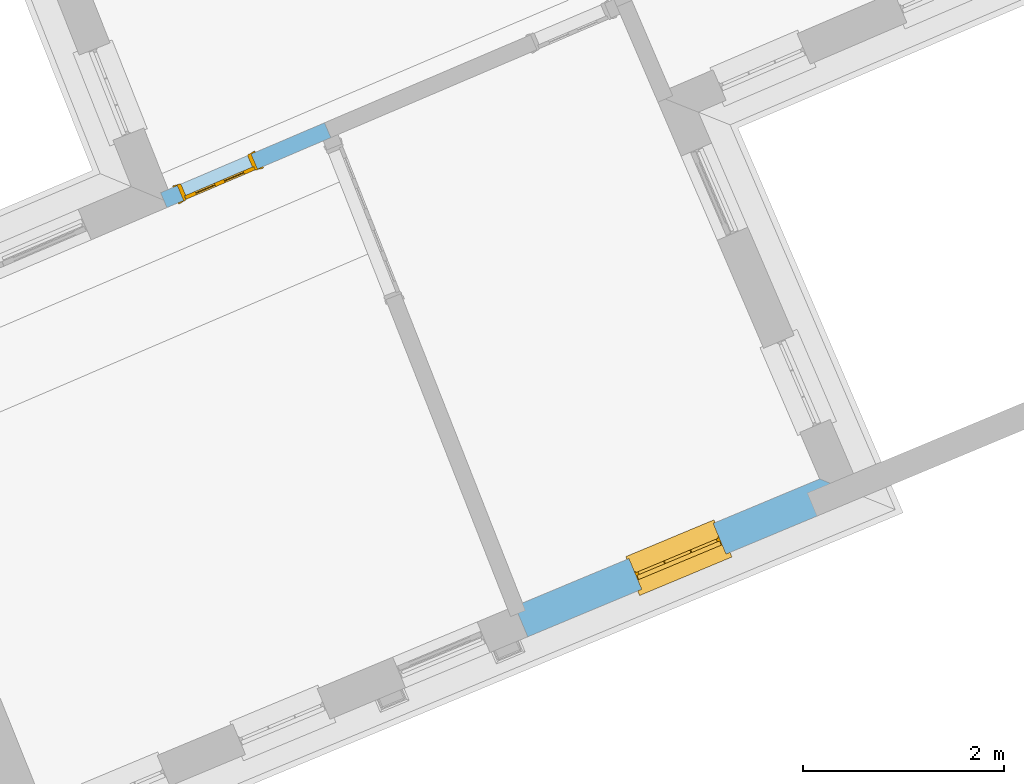
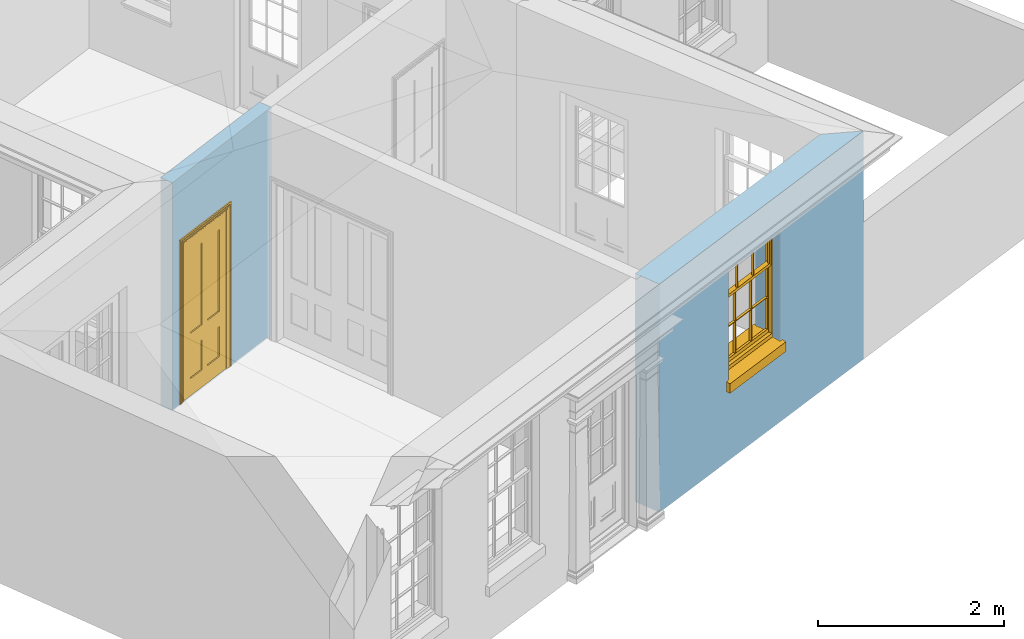
# One storey, part 5 of 19: 1 door, 1 window, 2 openings, plus 2 elements that do not belong to this part.
"""IFC2X3 building model written with IfcOpenShell, lengths in metres."""

from ifc_helpers import new_model, si_unit, frame, origin, place, context, subcontext, project, spatial, polyline, outline, extrude, faceted_brep, material, layer, layer_set, layer_usage, element, fill, save


model = new_model("IFC2X3")

# Units and contexts
model_context = context("Model", 3, world=origin())
body_context = subcontext(model_context, "Body", "Model", "MODEL_VIEW")
ifc_project = project(units=[si_unit("PLANEANGLEUNIT", "RADIAN"), si_unit("MASSUNIT", "GRAM", prefix="KILO"), si_unit("FORCEUNIT", "NEWTON", prefix="KILO"), si_unit("LENGTHUNIT", "METRE")], contexts=[model_context])

# Site, building, storey
site_placement = place(None, origin())
site = spatial("IfcSite", under=ifc_project, at=site_placement, CompositionType="ELEMENT")
building_placement = place(None, origin())
building = spatial("IfcBuilding", under=site, at=building_placement, Name="Building plot-0", CompositionType="ELEMENT")
storey_placement = place(None, origin())
storey = spatial("IfcBuildingStorey", under=building, at=storey_placement, Name="Floor 0", CompositionType="ELEMENT", Elevation=0.0)

# Wall, opening, window
ifc_material_1 = material(Name="Masonry")
ifc_layer_1 = layer(ifc_material_1, 0.33, ventilated=False)
ifc_layer_set_1 = layer_set([ifc_layer_1], Name="My Wall")
ifc_layer_usage_1 = layer_usage(ifc_layer_set_1, "AXIS2", "NEGATIVE", 0.08)
wall_1_placement = place(storey_placement, origin())
wall_1 = element("IfcWallStandardCase", 1, at=wall_1_placement, inside=storey, material=ifc_layer_usage_1, Name="exterior", context=body_context, shape_type="SweptSolid", body=[
    extrude(outline(polyline([(21.1736725194713, 22.591048436714), (21.3007494176732, 22.2864971898878), (24.6386025500617, 23.6792480885884), (24.2038471452139, 23.8554175583724), (21.1736725194713, 22.591048436714)])), origin(), (0.0, 0.0, 1.0), 3.0),
])
opening_1_placement = place(storey_placement, frame((0.0, 0.0, 1.05)))
opening_1 = element("IfcOpeningElement", 2, at=opening_1_placement, cuts=wall_1, Name="Opening", ObjectType="Opening", context=body_context, shape_type="SweptSolid", body=[
    extrude(outline(polyline([(22.4332195273928, 22.7590310913225), (23.2730426625801, 23.1094552651521), (23.1459657643782, 23.4140065119782), (22.3061426291909, 23.0635823381487), (22.4332195273928, 22.7590310913225)])), origin(), (0.0, 0.0, 1.0), 1.445),
])
window_placement = place(storey_placement, frame((22.3369491499671, 22.9897517328575, 1.05), z_axis=(0.0, 0.0, 1.0), x_axis=(0.839823135187327, 0.350424173829566, 0.0)))
window = element("IfcWindow", 3, at=window_placement, inside=storey, Name="kitchen street window", OverallHeight=1.445, OverallWidth=0.91, context=body_context, shape_type="Brep", held_by="IfcProductRepresentation", body=[
    faceted_brep([(0.876875, -0.105, 0.999097), (0.876875, -0.105, 1.411875), (0.9, -0.105, 1.435), (0.033125, -0.105, 1.411875), (0.033125, -0.105, 0.999097), (0.01, -0.105, 1.435), (0.033125, -0.135, 1.411875), (0.01, -0.135, 1.435), (0.033125, -0.135, 0.999097), (0.876875, -0.135, 1.411875), (0.876875, -0.135, 0.999097), (0.9, -0.135, 1.435), (0.033125, -0.105, 0.960972), (0.01, -0.105, 0.960972), (0.033125, -0.105, 0.548195), (0.876875, -0.105, 0.960972), (0.876875, -0.105, 0.548195), (0.9, -0.105, 0.960972), (0.876875, -0.105, 0.538195), (0.876875, -0.105, 0.125417), (0.9, -0.105, 0.077167), (0.033125, -0.105, 0.125417), (0.033125, -0.105, 0.538195), (0.01, -0.105, 0.077167), (0.9, -0.135, 0.960972), (0.01, -0.135, 0.960972), (-0.0425, -0.25, 0.01), (-0.0425, -0.3, 0.001667), (0.0, -0.25, 0.01), (0.9525, -0.25, 0.01), (0.91, -0.25, 0.01), (0.9525, -0.3, 0.001667), (-0.02, 0.08, 0.077167), (0.0, 0.08, 0.077167), (-0.02, 0.11, 0.077167), (0.0, -0.06, 0.077167), (0.01, -0.06, 0.077167), (0.91, -0.06, 0.077167), (0.91, 0.08, 0.077167), (0.9, -0.06, 0.077167), (0.93, 0.08, 0.077167), (0.93, 0.11, 0.077167), (0.01, -0.105, 0.999097), (0.01, -0.075, 0.999097), (0.9, -0.105, 0.999097), (0.9, -0.075, 0.999097), (0.876875, -0.075, 0.125417), (0.876875, -0.075, 0.538195), (0.9, -0.075, 0.077167), (0.876875, -0.075, 0.548195), (0.876875, -0.075, 0.960972), (0.033125, -0.075, 0.125417), (0.01, -0.075, 0.077167), (0.033125, -0.075, 0.538195), (0.033125, -0.075, 0.960972), (0.033125, -0.075, 0.548195), (-0.02, 0.08, 0.052167), (-0.02, 0.11, 0.052167), (0.93, 0.11, 0.052167), (0.93, 0.08, 0.052167), (0.91, 0.08, 0.052167), (0.0, 0.08, 0.052167), (0.91, -0.15, 0.026667), (0.0, -0.15, 0.026667), (-0.0425, -0.3, -0.123333), (0.9525, -0.3, -0.123333), (-0.0425, -0.25, -0.123333), (0.9525, -0.25, -0.123333), (0.01, -0.06, 1.435), (0.9, -0.06, 1.435), (0.0, -0.06, 1.445), (0.91, -0.06, 1.445), (0.01, -0.15, 0.077167), (0.9, -0.15, 0.077167), (0.592292, -0.105, 0.125417), (0.592292, -0.075, 0.125417), (0.317708, -0.075, 0.125417), (0.317708, -0.105, 0.125417), (0.592292, -0.105, 0.548195), (0.317708, -0.105, 0.548195), (0.317708, -0.105, 0.538195), (0.592292, -0.105, 0.538195), (0.592292, -0.075, 0.548195), (0.317708, -0.075, 0.548195), (0.602292, -0.075, 0.548195), (0.602292, -0.105, 0.548195), (0.317708, -0.075, 0.538195), (0.307708, -0.075, 0.125417), (0.307708, -0.075, 0.538195), (0.602292, -0.075, 0.538195), (0.602292, -0.075, 0.125417), (0.592292, -0.075, 0.538195), (0.307708, -0.075, 0.548195), (0.317708, -0.075, 0.960972), (0.307708, -0.075, 0.960972), (0.602292, -0.075, 0.960972), (0.592292, -0.075, 0.960972), (0.307708, -0.105, 0.538195), (0.307708, -0.105, 0.125417), (0.307708, -0.105, 0.548195), (0.307708, -0.105, 0.960972), (0.592292, -0.105, 0.960972), (0.317708, -0.105, 0.960972), (0.602292, -0.105, 0.960972), (0.602292, -0.105, 0.538195), (0.602292, -0.105, 0.125417), (0.317708, -0.135, 1.411875), (0.307708, -0.135, 1.411875), (0.307708, -0.135, 0.999097), (0.317708, -0.135, 0.999097), (0.602292, -0.135, 1.411875), (0.592292, -0.135, 1.411875), (0.592292, -0.135, 0.999097), (0.602292, -0.135, 0.999097), (0.317708, -0.105, 0.999097), (0.307708, -0.105, 0.999097), (0.307708, -0.105, 1.411875), (0.317708, -0.105, 1.411875), (0.602292, -0.105, 0.999097), (0.592292, -0.105, 0.999097), (0.592292, -0.105, 1.411875), (0.602292, -0.105, 1.411875), (0.91, -0.15, 1.445), (0.9, -0.15, 1.435), (0.01, -0.15, 1.435), (0.0, -0.15, 1.445), (0.91, -0.25, 0.0), (0.0, -0.25, 0.0), (0.91, 0.08, 0.0), (0.0, 0.08, 0.0)], [[[0, 1, 2]], [[3, 4, 5]], [[6, 7, 8]], [[9, 10, 11]], [[12, 13, 14]], [[15, 16, 17]], [[18, 19, 20]], [[21, 22, 23]], [[24, 15, 17]], [[13, 12, 25]], [[26, 27, 28]], [[29, 30, 31]], [[32, 33, 34]], [[35, 36, 33]], [[37, 38, 39]], [[40, 41, 38]], [[42, 4, 43]], [[44, 45, 0]], [[46, 47, 48]], [[49, 50, 45]], [[51, 52, 53]], [[54, 55, 43]], [[38, 33, 36, 39]], [[41, 34, 33, 38]], [[56, 32, 34, 57]], [[57, 34, 41, 58]], [[58, 41, 40, 59]], [[57, 58, 60, 61]], [[52, 48, 39, 36]], [[62, 63, 28, 30]], [[27, 31, 30, 28]], [[27, 64, 65, 31]], [[66, 67, 65, 64]], [[2, 5, 68, 69]], [[68, 70, 71, 69]], [[20, 23, 72, 73]], [[73, 72, 63, 62]], [[74, 75, 76, 77]], [[78, 79, 80, 81]], [[78, 82, 83, 79]], [[16, 49, 84, 85]], [[86, 76, 87, 88]], [[89, 90, 75, 91]], [[92, 88, 53, 55]], [[82, 91, 86, 83]], [[93, 83, 92, 94]], [[95, 84, 82, 96]], [[89, 84, 49, 47]], [[97, 88, 87, 98]], [[22, 53, 88, 97]], [[81, 91, 75, 74]], [[80, 86, 91, 81]], [[77, 76, 86, 80]], [[99, 92, 55, 14]], [[100, 94, 92, 99]], [[101, 96, 82, 78]], [[79, 83, 93, 102]], [[85, 84, 95, 103]], [[104, 89, 47, 18]], [[105, 90, 89, 104]], [[104, 18, 16, 85]], [[80, 97, 98, 77]], [[104, 81, 74, 105]], [[103, 101, 78, 85]], [[99, 14, 22, 97]], [[102, 100, 99, 79]], [[106, 107, 108, 109]], [[110, 111, 112, 113]], [[114, 115, 116, 117]], [[118, 119, 120, 121]], [[107, 116, 115, 108]], [[111, 120, 119, 112]], [[109, 114, 117, 106]], [[113, 118, 121, 110]], [[85, 78, 81, 104]], [[84, 89, 91, 82]], [[83, 86, 88, 92]], [[79, 99, 97, 80]], [[109, 112, 119, 114]], [[102, 93, 96, 101]], [[106, 117, 120, 111]], [[98, 87, 51, 21]], [[6, 3, 116, 107]], [[110, 121, 1, 9]], [[19, 46, 90, 105]], [[26, 66, 64, 27]], [[29, 31, 65, 67]], [[25, 24, 112, 109]], [[11, 7, 106, 111]], [[75, 48, 52, 76]], [[43, 45, 96, 93]], [[45, 43, 114, 119]], [[5, 2, 120, 117]], [[24, 25, 102, 101]], [[42, 5, 4]], [[2, 44, 0]], [[49, 45, 48, 47]], [[52, 43, 55, 53]], [[14, 13, 23, 22]], [[20, 17, 16, 18]], [[24, 11, 10]], [[25, 8, 7]], [[8, 4, 3, 6]], [[9, 1, 0, 10]], [[15, 50, 49, 16]], [[18, 47, 46, 19]], [[21, 51, 53, 22]], [[14, 55, 54, 12]], [[44, 2, 69, 45]], [[68, 5, 42, 43]], [[36, 35, 70, 68]], [[39, 69, 71, 37]], [[62, 122, 123, 73]], [[63, 72, 124, 125]], [[8, 108, 115, 4]], [[113, 10, 0, 118]], [[94, 100, 12, 54]], [[17, 20, 73, 24]], [[72, 23, 13, 25]], [[52, 36, 68, 43]], [[69, 39, 48, 45]], [[11, 24, 73, 123]], [[7, 124, 72, 25]], [[23, 77, 98]], [[98, 21, 23]], [[105, 74, 20]], [[20, 19, 105]], [[20, 74, 77, 23]], [[113, 112, 24]], [[24, 10, 113]], [[25, 109, 108]], [[108, 8, 25]], [[110, 9, 11]], [[11, 111, 110]], [[7, 6, 107]], [[107, 106, 7]], [[5, 117, 116]], [[116, 3, 5]], [[121, 120, 2]], [[2, 1, 121]], [[11, 123, 124, 7]], [[122, 125, 124, 123]], [[43, 93, 94]], [[94, 54, 43]], [[96, 45, 95]], [[50, 95, 45]], [[15, 103, 95, 50]], [[48, 75, 90]], [[90, 46, 48]], [[87, 76, 52]], [[52, 51, 87]], [[103, 15, 24]], [[24, 101, 103]], [[100, 102, 25]], [[25, 12, 100]], [[115, 114, 43]], [[43, 4, 115]], [[118, 0, 45]], [[45, 119, 118]], [[71, 70, 125, 122]], [[70, 35, 63, 125]], [[122, 62, 37, 71]], [[126, 67, 66, 127]], [[60, 58, 59]], [[38, 60, 59, 40]], [[61, 56, 57]], [[32, 56, 61, 33]], [[61, 60, 128, 129]], [[62, 60, 38, 37]], [[126, 128, 60, 62]], [[33, 61, 63, 35]], [[61, 129, 127, 63]], [[128, 126, 127, 129]], [[28, 127, 66, 26]], [[63, 127, 28]], [[29, 67, 126, 30]], [[30, 126, 62]]]),
])
fill(opening_1, window)

# Wall, opening, door
ifc_material_2 = material(Name="Masonry")
ifc_layer_2 = layer(ifc_material_2, 0.16, ventilated=False)
ifc_layer_set_2 = layer_set([ifc_layer_2], Name="My Wall")
ifc_layer_usage_2 = layer_usage(ifc_layer_set_2, "AXIS2", "NEGATIVE", 0.08)
wall_2_placement = place(storey_placement, origin())
wall_2 = element("IfcWallStandardCase", 4, at=wall_2_placement, inside=storey, material=ifc_layer_usage_2, Name="interior", context=body_context, shape_type="SweptSolid", body=[
    extrude(outline(polyline([(19.3430669615519, 27.2499335331589), (19.2802656397847, 27.3970932898327), (17.6500140012353, 26.701373481455), (17.7128153230025, 26.5542137247812), (19.3430669615519, 27.2499335331589)])), origin(), (0.0, 0.0, 1.0), 3.0),
])
opening_2_placement = place(storey_placement, frame((0.0, 0.0, 0.02)))
opening_2 = element("IfcOpeningElement", 5, at=opening_2_placement, cuts=wall_2, Name="Opening", ObjectType="Opening", context=body_context, shape_type="SweptSolid", body=[
    extrude(outline(polyline([(18.5513675108624, 27.086031577279), (17.8155687274933, 26.7720249684431), (17.8783700492605, 26.6248652117693), (18.6141688326296, 26.9388718206052), (18.5513675108624, 27.086031577279)])), origin(), (0.0, 0.0, 1.0), 2.1),
])
door_placement = place(storey_placement, frame((18.582768171746, 27.0124516989421, 0.02), z_axis=(0.0, 0.0, 1.0), x_axis=(-0.735798783369056, -0.3140066088359, 0.0)))
door = element("IfcDoor", 6, at=door_placement, inside=storey, Name="living inside door", OverallHeight=2.1, OverallWidth=0.8, context=body_context, shape_type="Brep", held_by="IfcProductRepresentation", body=[
    faceted_brep([(0.773, 0.08, 1.895), (0.66, 0.08, 1.895), (0.66, 0.08, 2.073), (0.773, 0.08, 2.073), (0.773, 0.08, 0.82), (0.66, 0.08, 0.82), (0.45, 0.08, 1.895), (0.45, 0.08, 2.073), (0.773, 0.08, 0.62), (0.66, 0.08, 0.62), (0.66, 0.065, 0.82), (0.66, 0.065, 1.895), (0.45, 0.065, 1.895), (0.35, 0.08, 1.895), (0.35, 0.08, 2.073), (0.773, 0.08, 0.225), (0.66, 0.08, 0.225), (0.45, 0.08, 0.62), (0.45, 0.08, 0.82), (0.45, 0.065, 0.82), (0.35, 0.08, 0.82), (0.14, 0.08, 2.073), (0.14, 0.08, 1.895), (0.773, 0.08, 0.0), (0.66, 0.08, 0.0), (0.66, 0.065, 0.225), (0.66, 0.065, 0.62), (0.45, 0.065, 0.62), (0.35, 0.08, 0.62), (0.35, 0.065, 0.82), (0.35, 0.065, 1.895), (0.14, 0.065, 1.895), (0.027, 0.08, 2.073), (0.027, 0.08, 1.895), (0.773, 0.042, 0.0), (0.66, 0.042, 0.0), (0.45, 0.08, 0.0), (0.45, 0.08, 0.225), (0.45, 0.065, 0.225), (0.35, 0.08, 0.225), (0.14, 0.08, 0.82), (0.14, 0.08, 0.62), (0.14, 0.065, 0.82), (0.027, 0.08, 0.82), (0.773, 0.042, 0.225), (0.66, 0.042, 0.225), (0.45, 0.042, 0.0), (0.35, 0.08, 0.0), (0.35, 0.065, 0.225), (0.35, 0.065, 0.62), (0.14, 0.065, 0.62), (0.027, 0.08, 0.62), (0.773, 0.042, 0.62), (0.66, 0.042, 0.62), (0.45, 0.042, 0.225), (0.35, 0.042, 0.0), (0.14, 0.08, 0.225), (0.14, 0.08, 0.0), (0.14, 0.065, 0.225), (0.027, 0.08, 0.225), (0.773, 0.042, 0.82), (0.66, 0.042, 0.82), (0.66, 0.057, 0.62), (0.66, 0.057, 0.225), (0.45, 0.057, 0.225), (0.35, 0.042, 0.225), (0.14, 0.042, 0.0), (0.027, 0.08, 0.0), (0.773, 0.042, 1.895), (0.66, 0.042, 1.895), (0.45, 0.042, 0.62), (0.45, 0.042, 0.82), (0.45, 0.057, 0.62), (0.35, 0.042, 0.62), (0.14, 0.042, 0.225), (0.027, 0.042, 0.0), (0.773, 0.042, 2.073), (0.66, 0.042, 2.073), (0.66, 0.057, 1.895), (0.66, 0.057, 0.82), (0.45, 0.057, 0.82), (0.35, 0.042, 0.82), (0.35, 0.057, 0.62), (0.35, 0.057, 0.225), (0.14, 0.057, 0.225), (0.027, 0.042, 0.225), (0.45, 0.042, 1.895), (0.45, 0.042, 2.073), (0.45, 0.057, 1.895), (0.35, 0.042, 1.895), (0.14, 0.042, 0.82), (0.14, 0.042, 0.62), (0.14, 0.057, 0.62), (0.027, 0.042, 0.62), (0.35, 0.042, 2.073), (0.35, 0.057, 1.895), (0.35, 0.057, 0.82), (0.14, 0.057, 0.82), (0.027, 0.042, 0.82), (0.14, 0.042, 2.073), (0.14, 0.042, 1.895), (0.14, 0.057, 1.895), (0.027, 0.042, 1.895), (0.027, 0.042, 2.073), (0.02, 0.085, 0.0), (0.005, 0.09, 0.0), (0.005, 0.09, 2.095), (0.02, 0.085, 2.08), (0.02, 0.08, 0.0), (0.0, 0.085, 0.0), (0.0, 0.085, 2.1), (0.795, 0.09, 2.095), (0.78, 0.085, 2.08), (0.02, 0.08, 2.08), (0.0, 0.08, 0.0), (-0.032, 0.095, 0.0), (-0.032, 0.095, 2.132), (0.8, 0.085, 2.1), (0.795, 0.09, 0.0), (0.78, 0.085, 0.0), (0.78, 0.08, 2.08), (0.04, 0.04, 0.0), (0.025, 0.04, 0.0), (0.025, 0.04, 2.075), (0.04, 0.04, 2.06), (-0.04, 0.09, 0.0), (-0.04, 0.09, 2.14), (0.832, 0.095, 2.132), (0.8, 0.085, 0.0), (0.78, 0.08, 0.0), (0.8, 0.08, 0.0), (0.86, 0.08, 0.0), (0.86, 0.08, 2.16), (0.8, 0.08, 2.1), (-0.06, 0.08, 2.16), (0.0, 0.08, 2.1), (-0.06, 0.08, 0.0), (-0.04, 0.095, 0.0), (-0.04, 0.095, 2.14), (0.84, 0.09, 2.14), (0.832, 0.095, 0.0), (0.84, 0.09, 0.0), (0.86, 0.095, 0.0), (0.86, 0.095, 2.16), (-0.06, 0.095, 2.16), (-0.06, 0.095, 0.0), (0.84, 0.095, 0.0), (0.84, 0.095, 2.14), (-0.025, -0.095, 0.0), (-0.025, -0.09, 0.0), (-0.025, -0.09, 2.125), (-0.025, -0.095, 2.125), (-0.017, -0.095, 0.0), (-0.017, -0.095, 2.117), (0.825, -0.09, 2.125), (0.825, -0.095, 2.125), (0.825, -0.095, 0.0), (0.845, -0.095, 0.0), (-0.045, -0.095, 2.145), (-0.045, -0.095, 0.0), (0.845, -0.095, 2.145), (0.015, -0.085, 0.0), (0.015, -0.085, 2.085), (0.817, -0.095, 2.117), (0.825, -0.09, 0.0), (0.845, -0.08, 0.0), (0.845, -0.08, 2.145), (-0.045, -0.08, 2.145), (-0.045, -0.08, 0.0), (0.02, -0.09, 0.0), (0.02, -0.09, 2.08), (0.785, -0.085, 2.085), (0.817, -0.095, 0.0), (0.8, -0.08, 0.0), (0.8, -0.08, 2.1), (0.0, -0.08, 2.1), (0.0, -0.08, 0.0), (0.035, -0.085, 0.0), (0.035, -0.085, 2.065), (0.78, -0.09, 2.08), (0.785, -0.085, 0.0), (0.775, 0.04, 2.075), (0.76, 0.04, 2.06), (0.035, -0.08, 2.065), (0.035, -0.08, 0.0), (0.765, -0.085, 2.065), (0.78, -0.09, 0.0), (0.765, -0.08, 0.0), (0.765, -0.08, 2.065), (0.765, -0.085, 0.0), (0.04, -0.08, 2.06), (0.04, -0.08, 0.0), (0.76, -0.08, 2.06), (0.76, -0.08, 0.0), (0.76, 0.04, 0.0), (0.775, 0.04, 0.0), (0.025, 0.08, 0.0), (0.025, 0.08, 2.075), (0.775, 0.08, 0.0), (0.775, 0.08, 2.075)], [[[0, 1, 2, 3]], [[1, 0, 4, 5]], [[1, 6, 7, 2]], [[8, 9, 5, 4]], [[1, 5, 10, 11]], [[6, 1, 11, 12]], [[6, 13, 14, 7]], [[15, 16, 9, 8]], [[9, 17, 18, 5]], [[5, 18, 19, 10]], [[10, 19, 12, 11]], [[18, 6, 12, 19]], [[18, 20, 13, 6]], [[21, 14, 13, 22]], [[23, 24, 16, 15]], [[9, 16, 25, 26]], [[17, 9, 26, 27]], [[17, 28, 20, 18]], [[13, 20, 29, 30]], [[22, 13, 30, 31]], [[32, 21, 22, 33]], [[34, 35, 24, 23]], [[24, 36, 37, 16]], [[16, 37, 38, 25]], [[25, 38, 27, 26]], [[37, 17, 27, 38]], [[37, 39, 28, 17]], [[40, 20, 28, 41]], [[20, 40, 42, 29]], [[31, 30, 29, 42]], [[40, 22, 31, 42]], [[33, 22, 40, 43]], [[35, 34, 44, 45]], [[35, 46, 36, 24]], [[36, 47, 39, 37]], [[28, 39, 48, 49]], [[41, 28, 49, 50]], [[43, 40, 41, 51]], [[45, 44, 52, 53]], [[46, 35, 45, 54]], [[46, 55, 47, 36]], [[56, 39, 47, 57]], [[39, 56, 58, 48]], [[50, 49, 48, 58]], [[56, 41, 50, 58]], [[51, 41, 56, 59]], [[53, 52, 60, 61]], [[45, 53, 62, 63]], [[54, 45, 63, 64]], [[55, 46, 54, 65]], [[55, 66, 57, 47]], [[59, 56, 57, 67]], [[61, 60, 68, 69]], [[70, 53, 61, 71]], [[53, 70, 72, 62]], [[72, 64, 63, 62]], [[70, 54, 64, 72]], [[65, 54, 70, 73]], [[65, 74, 66, 55]], [[67, 57, 66, 75]], [[69, 68, 76, 77]], [[61, 69, 78, 79]], [[71, 61, 79, 80]], [[73, 70, 71, 81]], [[65, 73, 82, 83]], [[74, 65, 83, 84]], [[74, 85, 75, 66]], [[86, 69, 77, 87]], [[69, 86, 88, 78]], [[88, 80, 79, 78]], [[86, 71, 80, 88]], [[81, 71, 86, 89]], [[73, 81, 90, 91]], [[73, 91, 92, 82]], [[83, 82, 92, 84]], [[91, 74, 84, 92]], [[91, 93, 85, 74]], [[89, 86, 87, 94]], [[81, 89, 95, 96]], [[90, 81, 96, 97]], [[90, 98, 93, 91]], [[94, 99, 100, 89]], [[89, 100, 101, 95]], [[101, 97, 96, 95]], [[100, 90, 97, 101]], [[100, 102, 98, 90]], [[99, 103, 102, 100]], [[32, 103, 99, 21]], [[102, 103, 32, 33]], [[98, 102, 33, 43]], [[21, 99, 94, 14]], [[94, 87, 7, 14]], [[7, 87, 77, 2]], [[76, 3, 2, 77]], [[43, 51, 93, 98]], [[51, 59, 85, 93]], [[67, 75, 85, 59]], [[34, 23, 15, 44]], [[44, 15, 8, 52]], [[52, 8, 4, 60]], [[0, 68, 60, 4]], [[0, 3, 76, 68]], [[104, 105, 106, 107]], [[104, 108, 109, 105]], [[105, 109, 110, 106]], [[107, 106, 111, 112]], [[107, 113, 108, 104]], [[114, 109, 108]], [[109, 115, 116, 110]], [[106, 110, 117, 111]], [[112, 111, 118, 119]], [[113, 107, 112, 120]], [[121, 122, 123, 124]], [[115, 109, 114, 125]], [[115, 125, 126, 116]], [[110, 116, 127, 117]], [[111, 117, 128, 118]], [[118, 128, 129, 119]], [[120, 112, 119, 129]], [[130, 129, 128]], [[130, 131, 132, 133]], [[133, 132, 134, 135]], [[135, 134, 136, 114]], [[136, 125, 114]], [[125, 137, 138, 126]], [[116, 126, 139, 127]], [[117, 127, 140, 128]], [[141, 130, 128, 140]], [[131, 130, 141]], [[131, 142, 143, 132]], [[132, 143, 144, 134]], [[134, 144, 145, 136]], [[137, 125, 136, 145]], [[143, 142, 146]], [[143, 146, 147]], [[137, 145, 144]], [[143, 147, 138]], [[138, 137, 144]], [[143, 138, 144]], [[126, 138, 147, 139]], [[127, 139, 141, 140]], [[142, 131, 141, 146]], [[139, 147, 146, 141]], [[148, 149, 150, 151]], [[149, 152, 153, 150]], [[151, 150, 154, 155]], [[155, 156, 157]], [[158, 159, 148]], [[158, 148, 151]], [[155, 157, 160]], [[158, 151, 155]], [[155, 160, 158]], [[152, 161, 162, 153]], [[150, 153, 163, 154]], [[155, 154, 164, 156]], [[156, 164, 165, 157]], [[157, 165, 166, 160]], [[160, 166, 167, 158]], [[158, 167, 168, 159]], [[161, 169, 170, 162]], [[153, 162, 171, 163]], [[154, 163, 172, 164]], [[165, 164, 173]], [[165, 173, 174, 166]], [[166, 174, 175, 167]], [[167, 175, 176, 168]], [[169, 177, 178, 170]], [[162, 170, 179, 171]], [[163, 171, 180, 172]], [[172, 180, 173, 164]], [[124, 123, 181, 182]], [[183, 178, 177, 184]], [[170, 178, 185, 179]], [[171, 179, 186, 180]], [[187, 173, 180]], [[185, 188, 187, 189]], [[188, 185, 178, 183]], [[179, 185, 189, 186]], [[189, 187, 180, 186]], [[190, 183, 184, 191]], [[192, 188, 183, 190]], [[191, 184, 122, 121]], [[124, 190, 191, 121]], [[193, 187, 188, 192]], [[182, 192, 190, 124]], [[184, 176, 122]], [[194, 195, 187, 193]], [[192, 182, 194, 193]], [[161, 176, 184]], [[114, 108, 122, 176]], [[173, 187, 195]], [[152, 149, 176, 161]], [[169, 161, 184, 177]], [[196, 122, 108]], [[176, 175, 135, 114]], [[173, 195, 129, 130]], [[176, 149, 168]], [[123, 122, 196, 197]], [[196, 108, 113, 197]], [[175, 174, 133, 135]], [[198, 129, 195]], [[133, 174, 173, 130]], [[159, 168, 149, 148]], [[181, 123, 197, 199]], [[197, 113, 120, 199]], [[199, 120, 129, 198]], [[195, 181, 199, 198]], [[195, 194, 182, 181]]]),
])
fill(opening_2, door)

save(model, "model.ifc")
